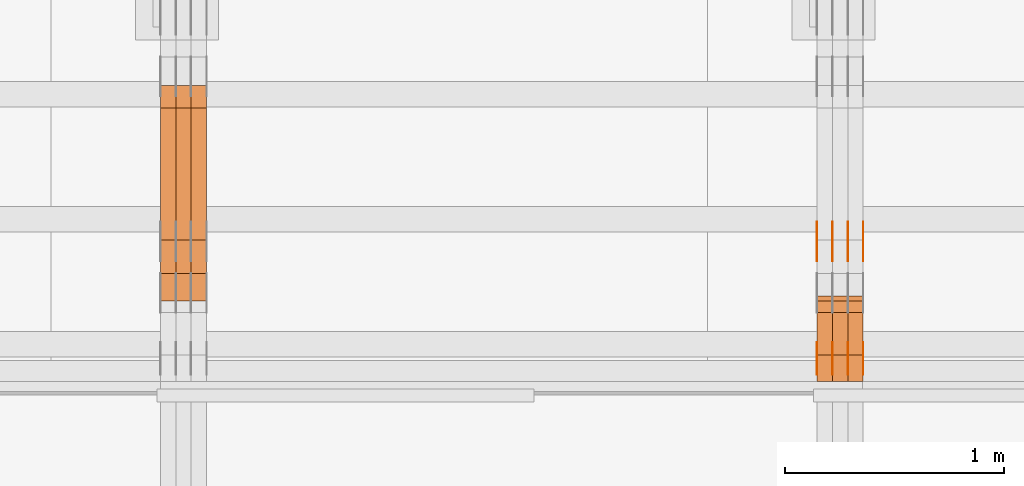
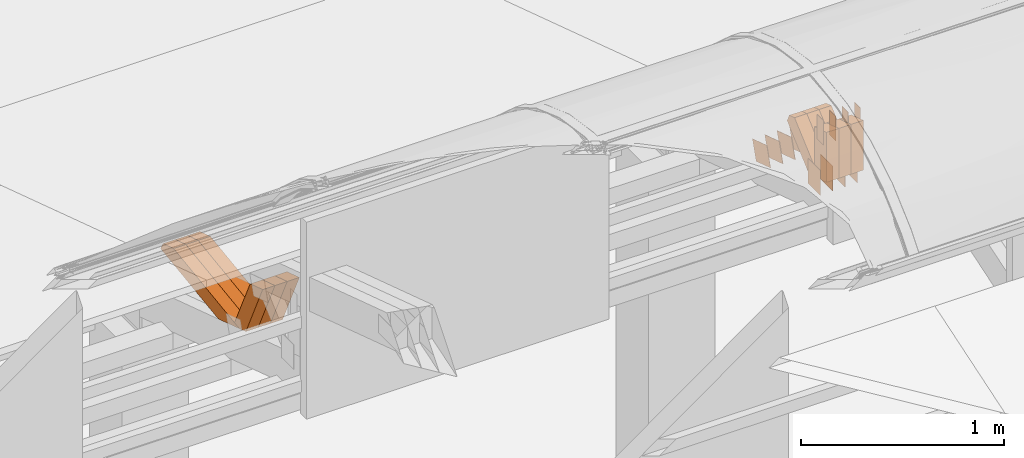
# One storey, part 162 of 385: 30 proxies.
"""IFC2X3 building model written with IfcOpenShell, lengths in millimetres."""

import ifcopenshell
import ifcopenshell.guid

model = None  # the IFC model being written
_history = None  # IfcOwnerHistory: only IFC2X3 demands one
_inside = {}  # id of a spatial element -> (the spatial element, [elements in it])
_under = {}  # id of a project, library or spatial element -> (it, [spatial elements below it])
_declared = {}  # id of a project -> (the project, [libraries it declares])
_typed = {}  # id of a type object -> (the type object, [elements of that type])
_made_of = {}  # id of a material, layer set ... -> (it, [elements and type objects made of it])


def new_model(schema):
    """Start an empty IFC model of exactly this schema.

    Asked for "IFC4X3", IfcOpenShell would pick the latest addendum, in which some entities
    have other attributes; the version numbers below select the first issue.
    IFC2X3 requires an IfcOwnerHistory on every rooted entity: one is made here for all.
    """
    global model, _history
    if schema == "IFC4X3":
        model = ifcopenshell.file(schema_version=(4, 3, 0, 0))
    else:
        model = ifcopenshell.file(schema=schema)
    _inside.clear()
    _under.clear()
    _declared.clear()
    _typed.clear()
    _made_of.clear()
    _history = None
    if model.schema == "IFC2X3":
        org = make("IfcOrganization", Name="unknown")
        user = make(
            "IfcPersonAndOrganization",
            ThePerson=make("IfcPerson", FamilyName="unknown"),
            TheOrganization=org,
        )
        app = make(
            "IfcApplication",
            ApplicationDeveloper=org,
            Version="unknown",
            ApplicationFullName="unknown",
            ApplicationIdentifier="unknown",
        )
        _history = make(
            "IfcOwnerHistory",
            OwningUser=user,
            OwningApplication=app,
            ChangeAction="ADDED",
            CreationDate=0,
        )
    return model


def make(cls, **values):
    """One entity of the class cls with the attributes given. An attribute that is None is left unset."""
    return model.create_entity(
        cls, **{name: value for name, value in values.items() if value is not None}
    )


def entity(cls, *values):
    """Any entity or typed value of the class cls, its attributes in the order of the schema. None: left unset."""
    e = model.create_entity(cls)
    for i, value in enumerate(values):
        if value is not None:
            e[i] = value
    return e


def rooted(cls, **values):
    """An entity with a GlobalId (a new one), such as an element, a storey or a relation."""
    return make(cls, GlobalId=ifcopenshell.guid.new(), OwnerHistory=_history, **values)


def si_unit(unit_type, name, prefix=None):
    """IfcSIUnit, for example si_unit("LENGTHUNIT", "METRE", prefix="MILLI")."""
    return make("IfcSIUnit", UnitType=unit_type, Prefix=prefix, Name=name)


def converted_unit(unit_type, name, factor, base, dimensions=None, offset=None):
    """IfcConversionBasedUnit, such as the inch: factor (a typed value) times the base unit."""
    return make(
        "IfcConversionBasedUnit"
        if offset is None
        else "IfcConversionBasedUnitWithOffset",
        ConversionOffset=offset,
        Dimensions=None
        if dimensions is None
        else entity("IfcDimensionalExponents", *dimensions),
        UnitType=unit_type,
        Name=name,
        ConversionFactor=make(
            "IfcMeasureWithUnit", ValueComponent=factor, UnitComponent=base
        ),
    )


def derived_unit(unit_type, elements):
    """IfcDerivedUnit: a product of units, each with its exponent."""
    return make(
        "IfcDerivedUnit",
        Elements=[
            make("IfcDerivedUnitElement", Unit=unit, Exponent=power)
            for unit, power in elements
        ],
        UnitType=unit_type,
    )


def assignment(units):
    """IfcUnitAssignment: the units of a project."""
    return None if units is None else make("IfcUnitAssignment", Units=units)


def point(xyz):
    """IfcCartesianPoint."""
    return None if xyz is None else make("IfcCartesianPoint", Coordinates=xyz)


def direction(xyz):
    """IfcDirection."""
    return None if xyz is None else make("IfcDirection", DirectionRatios=xyz)


def frame(location, z_axis=None, x_axis=None):
    """IfcAxis2Placement3D, a coordinate frame: its origin and axes. An axis left out is left unset."""
    return make(
        "IfcAxis2Placement3D",
        Location=point(location),
        Axis=direction(z_axis),
        RefDirection=direction(x_axis),
    )


def frame_2d(location, x_axis=None):
    """IfcAxis2Placement2D, a coordinate frame in the plane: its origin and x axis."""
    return make(
        "IfcAxis2Placement2D", Location=point(location), RefDirection=direction(x_axis)
    )


def origin():
    """The frame at (0, 0, 0) with its axes left unset."""
    return frame((0.0, 0.0, 0.0))


def origin_2d_with_axis():
    """The frame at (0, 0) in the plane with the x axis (1, 0) written out."""
    return frame_2d((0.0, 0.0), x_axis=(1.0, 0.0))


def place(relative_to, where):
    """IfcLocalPlacement: puts the frame where relative to a parent placement (None: the world)."""
    return make(
        "IfcLocalPlacement", PlacementRelTo=relative_to, RelativePlacement=where
    )


def context(
    kind, dimensions, precision=None, world=None, true_north=None, identifier=None
):
    """IfcGeometricRepresentationContext, for example the 3D "Model" context."""
    return make(
        "IfcGeometricRepresentationContext",
        ContextIdentifier=identifier,
        ContextType=kind,
        CoordinateSpaceDimension=dimensions,
        Precision=precision,
        WorldCoordinateSystem=world,
        TrueNorth=true_north,
    )


def subcontext(parent, identifier, kind, view, scale=None):
    """IfcGeometricRepresentationSubContext, for example "Body" below "Model"."""
    return make(
        "IfcGeometricRepresentationSubContext",
        ContextIdentifier=identifier,
        ContextType=kind,
        ParentContext=parent,
        TargetScale=scale,
        TargetView=view,
    )


def project(units=None, contexts=None):
    """IfcProject with its units and contexts."""
    return rooted(
        "IfcProject",
        Name="project",
        RepresentationContexts=contexts,
        UnitsInContext=assignment(units),
    )


def spatial(cls, under=None, at=None, **own):
    """A site, building, storey or space (cls), placed at a placement, below another one or the project."""
    s = rooted(cls, ObjectPlacement=at, **own)
    if under is not None:
        _under.setdefault(under.id(), (under, []))[1].append(s)
    return s


def polyline(points):
    """IfcPolyline through the points."""
    return make("IfcPolyline", Points=[point(p) for p in points])


def profile(cls, at=None, kind="AREA", **sizes):
    """A parametric profile (cls). Its sizes go by their IFC names, for example OverallWidth=200.0."""
    return make(cls, ProfileType=kind, Position=at, **sizes)


def rectangle(**sizes):
    """IfcRectangleProfileDef."""
    return profile("IfcRectangleProfileDef", **sizes)


def outline(outer, holes=None, kind="AREA"):
    """IfcArbitraryClosedProfileDef: a profile drawn as a closed curve; with holes, ...WithVoids."""
    if holes is None:
        return make("IfcArbitraryClosedProfileDef", ProfileType=kind, OuterCurve=outer)
    return make(
        "IfcArbitraryProfileDefWithVoids",
        ProfileType=kind,
        OuterCurve=outer,
        InnerCurves=holes,
    )


def extrude(swept, where, along, depth):
    """IfcExtrudedAreaSolid: the profile swept, set in the frame where, extruded along a direction by depth."""
    return make(
        "IfcExtrudedAreaSolid",
        SweptArea=swept,
        Position=where,
        ExtrudedDirection=direction(along),
        Depth=depth,
    )


def shape(context_of_items, identifier, shape_type, items):
    """IfcShapeRepresentation: the items that make up one representation, for example the "Body"."""
    return make(
        "IfcShapeRepresentation",
        ContextOfItems=context_of_items,
        RepresentationIdentifier=identifier,
        RepresentationType=shape_type,
        Items=items,
    )


def source(mapping_origin, context_of_items, identifier, shape_type, items):
    """IfcRepresentationMap: a shape defined once, which mapped items show again and again."""
    return make(
        "IfcRepresentationMap",
        MappingOrigin=mapping_origin,
        MappedRepresentation=shape(context_of_items, identifier, shape_type, items),
    )


def transform(
    local_origin,
    x_axis=None,
    y_axis=None,
    z_axis=None,
    scale=None,
    scale2=None,
    scale3=None,
    uniform=True,
):
    """IfcCartesianTransformationOperator3D, or its non-uniform kind. x_axis, y_axis, z_axis: its Axis1, 2, 3."""
    if uniform:
        return make(
            "IfcCartesianTransformationOperator3D",
            Axis1=direction(x_axis),
            Axis2=direction(y_axis),
            LocalOrigin=point(local_origin),
            Scale=scale,
            Axis3=direction(z_axis),
        )
    return make(
        "IfcCartesianTransformationOperator3DnonUniform",
        Axis1=direction(x_axis),
        Axis2=direction(y_axis),
        LocalOrigin=point(local_origin),
        Scale=scale,
        Axis3=direction(z_axis),
        Scale2=scale2,
        Scale3=scale3,
    )


def mapped(mapping_source, mapping_target):
    """IfcMappedItem: shows the shape of a source again, moved by a transform."""
    return make(
        "IfcMappedItem", MappingSource=mapping_source, MappingTarget=mapping_target
    )


def material(Name=None, Category=None):
    """IfcMaterial."""
    return make("IfcMaterial", Name=Name, Category=Category)


def made_of(thing, what):
    """Note that an element or type object is made of a material, layer set ...; save() writes the relation."""
    if what is not None:
        _made_of.setdefault(what.id(), (what, []))[1].append(thing)
    return thing


def type_object(cls, material=None, **own):
    """A type object (cls), such as IfcWallType, which elements share."""
    return made_of(rooted(cls, **own), material)


def type_shapes(of_type, sources):
    """Give a type object the sources (RepresentationMaps) that its elements show as mapped items."""
    of_type.RepresentationMaps = sources


def element(
    cls,
    number,
    at=None,
    inside=None,
    cuts=None,
    type_object=None,
    material=None,
    context=None,
    identifier="Body",
    shape_type=None,
    held_by="IfcProductDefinitionShape",
    body=None,
    shapes=None,
    **own,
):
    """One element of the class cls, such as IfcWall. Its Tag is "e" and its number.

    at: its placement. inside: the storey or other place that contains it. cuts: it is an
    opening in that element (IfcRelVoidsElement). A single representation is given by context,
    identifier, shape_type and body (its items); several are given by shapes. held_by: the class
    of the entity that holds the representations. save() writes the other relations.
    """
    e = rooted(cls, Tag="e%d" % number, ObjectPlacement=at, **own)
    if body is not None:
        shapes = [shape(context, identifier, shape_type, body)]
    if shapes is not None:
        e.Representation = make(held_by, Representations=shapes)
    if inside is not None:
        _inside.setdefault(inside.id(), (inside, []))[1].append(e)
    if cuts is not None:
        rooted(
            "IfcRelVoidsElement", RelatingBuildingElement=cuts, RelatedOpeningElement=e
        )
    if type_object is not None:
        _typed.setdefault(type_object.id(), (type_object, []))[1].append(e)
    return made_of(e, material)


def aggregate(whole, parts):
    """IfcRelAggregates: a whole, such as a stair, and the parts it consists of."""
    return rooted("IfcRelAggregates", RelatingObject=whole, RelatedObjects=parts)


def save(model, path):
    """Write the relations noted so far, then the file.

    IfcRelAggregates (storeys below a building ...), IfcRelContainedInSpatialStructure (elements
    in a storey), IfcRelDefinesByType, IfcRelAssociatesMaterial and IfcRelDeclares: one each for
    every whole, place, type object, material and project.
    """
    for whole, parts in _under.values():
        aggregate(whole, parts)
    for where, things in _inside.values():
        rooted(
            "IfcRelContainedInSpatialStructure",
            RelatedElements=things,
            RelatingStructure=where,
        )
    for kind, things in _typed.values():
        rooted("IfcRelDefinesByType", RelatedObjects=things, RelatingType=kind)
    for what, things in _made_of.values():
        rooted("IfcRelAssociatesMaterial", RelatedObjects=things, RelatingMaterial=what)
    for by, libraries in _declared.values():
        rooted("IfcRelDeclares", RelatingContext=by, RelatedDefinitions=libraries)
    model.write(path)


model = new_model("IFC2X3")

# Units and contexts
model_context = context("Model", 3, precision=0.01, world=origin(), true_north=direction((6.12303176911189e-17, 1.0)))
body_context = subcontext(model_context, "Body", "Model", "MODEL_VIEW")
ifc_project = project(units=[si_unit("LENGTHUNIT", "METRE", prefix="MILLI"), si_unit("AREAUNIT", "SQUARE_METRE"), si_unit("VOLUMEUNIT", "CUBIC_METRE"), converted_unit("PLANEANGLEUNIT", "DEGREE", entity("IfcRatioMeasure", 0.0174532925199433), si_unit("PLANEANGLEUNIT", "RADIAN"), dimensions=[0, 0, 0, 0, 0, 0, 0]), si_unit("MASSUNIT", "GRAM", prefix="KILO"), derived_unit("MASSDENSITYUNIT", [(si_unit("MASSUNIT", "GRAM", prefix="KILO"), 1), (si_unit("LENGTHUNIT", "METRE"), -3)]), si_unit("TIMEUNIT", "SECOND"), si_unit("FREQUENCYUNIT", "HERTZ"), si_unit("THERMODYNAMICTEMPERATUREUNIT", "DEGREE_CELSIUS"), derived_unit("THERMALTRANSMITTANCEUNIT", [(si_unit("MASSUNIT", "GRAM", prefix="KILO"), 1), (si_unit("THERMODYNAMICTEMPERATUREUNIT", "KELVIN"), -1), (si_unit("TIMEUNIT", "SECOND"), -3)]), derived_unit("VOLUMETRICFLOWRATEUNIT", [(si_unit("LENGTHUNIT", "METRE"), 3), (si_unit("TIMEUNIT", "SECOND"), -1)]), si_unit("ELECTRICCURRENTUNIT", "AMPERE"), si_unit("ELECTRICVOLTAGEUNIT", "VOLT"), si_unit("POWERUNIT", "WATT"), si_unit("FORCEUNIT", "NEWTON", prefix="KILO"), si_unit("ILLUMINANCEUNIT", "LUX"), si_unit("LUMINOUSFLUXUNIT", "LUMEN"), si_unit("LUMINOUSINTENSITYUNIT", "CANDELA"), derived_unit("USERDEFINED", [(si_unit("MASSUNIT", "GRAM", prefix="KILO"), -1), (si_unit("LENGTHUNIT", "METRE"), -2), (si_unit("TIMEUNIT", "SECOND"), 3), (si_unit("LUMINOUSFLUXUNIT", "LUMEN"), 1)]), derived_unit("LINEARVELOCITYUNIT", [(si_unit("LENGTHUNIT", "METRE"), 1), (si_unit("TIMEUNIT", "SECOND"), -1)]), si_unit("PRESSUREUNIT", "PASCAL"), derived_unit("USERDEFINED", [(si_unit("LENGTHUNIT", "METRE"), -2), (si_unit("MASSUNIT", "GRAM", prefix="KILO"), 1), (si_unit("TIMEUNIT", "SECOND"), -2)])], contexts=[model_context])

# Site, building, storey
site_placement = place(None, origin())
site = spatial("IfcSite", under=ifc_project, at=site_placement, CompositionType="ELEMENT")
building_placement = place(site_placement, origin())
building = spatial("IfcBuilding", under=site, at=building_placement, CompositionType="ELEMENT")
storey_placement = place(building_placement, origin())
storey = spatial("IfcBuildingStorey", under=building, at=storey_placement, Name="Default", CompositionType="ELEMENT", Elevation=0.0)

# Proxies
ifc_material_1 = material(Name="IfcSurfaceStyle #343106")
building_element_proxy_type_1 = type_object("IfcBuildingElementProxyType", PredefinedType="NOTDEFINED", material=ifc_material_1)
shared_shape_1 = source(origin(), body_context, "Body", "SweptSolid", [
    extrude(rectangle(XDim=150.0, YDim=120.0, at=origin_2d_with_axis()), frame((75.0, 60.0, 0.0), z_axis=(0.0, 0.0, 1.0), x_axis=(-1.0, 0.0, 0.0)), (0.0, 0.0, 1.0), 1.3),
])
type_shapes(building_element_proxy_type_1, [shared_shape_1])
proxy_1_placement = place(building_placement, frame((27386.3, 15840.0, 3652.70166015625), z_axis=(-1.0, 0.0, 0.0), x_axis=(0.0, 0.0, -1.0)))
element("IfcBuildingElementProxy", 1, at=proxy_1_placement, inside=storey, type_object=building_element_proxy_type_1, material=ifc_material_1, context=body_context, shape_type="MappedRepresentation", body=[
    mapped(shared_shape_1, transform((0.0, 0.0, 0.0), scale=1.0)),
])
ifc_material_2 = material(Name="IfcSurfaceStyle #343049")
building_element_proxy_type_2 = type_object("IfcBuildingElementProxyType", PredefinedType="NOTDEFINED", material=ifc_material_2)
shared_shape_2 = source(origin(), body_context, "Body", "SweptSolid", [
    extrude(rectangle(XDim=150.0, YDim=120.0, at=origin_2d_with_axis()), frame((75.0, 60.0, 0.0), z_axis=(0.0, 0.0, 1.0), x_axis=(-1.0, 0.0, 0.0)), (0.0, 0.0, 1.0), 1.3),
])
type_shapes(building_element_proxy_type_2, [shared_shape_2])
proxy_2_placement = place(building_placement, frame((27315.0, 15840.0, 3652.70166015625), z_axis=(-1.0, 0.0, 0.0), x_axis=(0.0, 0.0, -1.0)))
element("IfcBuildingElementProxy", 2, at=proxy_2_placement, inside=storey, type_object=building_element_proxy_type_2, material=ifc_material_2, context=body_context, shape_type="MappedRepresentation", body=[
    mapped(shared_shape_2, transform((0.0, 0.0, 0.0), scale=1.0)),
])
ifc_material_3 = material(Name="IfcSurfaceStyle #342992")
building_element_proxy_type_3 = type_object("IfcBuildingElementProxyType", PredefinedType="NOTDEFINED", material=ifc_material_3)
shared_shape_3 = source(origin(), body_context, "Body", "SweptSolid", [
    extrude(rectangle(XDim=150.0, YDim=120.0, at=origin_2d_with_axis()), frame((75.0, 60.0, 0.0), z_axis=(0.0, 0.0, 1.0), x_axis=(-1.0, 0.0, 0.0)), (0.0, 0.0, 1.0), 1.3),
])
type_shapes(building_element_proxy_type_3, [shared_shape_3])
proxy_3_placement = place(building_placement, frame((27316.3, 15840.0, 3652.70166015625), z_axis=(-1.0, 0.0, 0.0), x_axis=(0.0, 0.0, -1.0)))
element("IfcBuildingElementProxy", 3, at=proxy_3_placement, inside=storey, type_object=building_element_proxy_type_3, material=ifc_material_3, context=body_context, shape_type="MappedRepresentation", body=[
    mapped(shared_shape_3, transform((0.0, 0.0, 0.0), scale=1.0)),
])
ifc_material_4 = material(Name="IfcSurfaceStyle #342935")
building_element_proxy_type_4 = type_object("IfcBuildingElementProxyType", PredefinedType="NOTDEFINED", material=ifc_material_4)
shared_shape_4 = source(origin(), body_context, "Body", "SweptSolid", [
    extrude(rectangle(XDim=150.0, YDim=120.0, at=origin_2d_with_axis()), frame((75.0, 60.0, 0.0), z_axis=(0.0, 0.0, 1.0), x_axis=(-1.0, 0.0, 0.0)), (0.0, 0.0, 1.0), 1.29999999999999),
])
type_shapes(building_element_proxy_type_4, [shared_shape_4])
proxy_4_placement = place(building_placement, frame((27245.0, 15840.0, 3652.70166015625), z_axis=(-1.0, 0.0, 0.0), x_axis=(0.0, 0.0, -1.0)))
element("IfcBuildingElementProxy", 4, at=proxy_4_placement, inside=storey, type_object=building_element_proxy_type_4, material=ifc_material_4, context=body_context, shape_type="MappedRepresentation", body=[
    mapped(shared_shape_4, transform((0.0, 0.0, 0.0), scale=1.0)),
])
ifc_material_5 = material(Name="IfcSurfaceStyle #342878")
building_element_proxy_type_5 = type_object("IfcBuildingElementProxyType", PredefinedType="NOTDEFINED", material=ifc_material_5)
shared_shape_5 = source(origin(), body_context, "Body", "SweptSolid", [
    extrude(rectangle(XDim=150.0, YDim=120.0, at=origin_2d_with_axis()), frame((75.0, 60.0, 0.0), z_axis=(0.0, 0.0, 1.0), x_axis=(-1.0, 0.0, 0.0)), (0.0, 0.0, 1.0), 1.29999999999999),
])
type_shapes(building_element_proxy_type_5, [shared_shape_5])
proxy_5_placement = place(building_placement, frame((27246.3, 15840.0, 3652.70166015625), z_axis=(-1.0, 0.0, 0.0), x_axis=(0.0, 0.0, -1.0)))
element("IfcBuildingElementProxy", 5, at=proxy_5_placement, inside=storey, type_object=building_element_proxy_type_5, material=ifc_material_5, context=body_context, shape_type="MappedRepresentation", body=[
    mapped(shared_shape_5, transform((0.0, 0.0, 0.0), scale=1.0)),
])
ifc_material_6 = material(Name="IfcSurfaceStyle #342821")
building_element_proxy_type_6 = type_object("IfcBuildingElementProxyType", PredefinedType="NOTDEFINED", material=ifc_material_6)
shared_shape_6 = source(origin(), body_context, "Body", "SweptSolid", [
    extrude(rectangle(XDim=150.0, YDim=120.0, at=origin_2d_with_axis()), frame((75.0, 60.0, 0.0), z_axis=(0.0, 0.0, 1.0), x_axis=(-1.0, 0.0, 0.0)), (0.0, 0.0, 1.0), 1.29999999999999),
])
type_shapes(building_element_proxy_type_6, [shared_shape_6])
proxy_6_placement = place(building_placement, frame((27175.0, 15840.0, 3652.70166015625), z_axis=(-1.0, 0.0, 0.0), x_axis=(0.0, 0.0, -1.0)))
element("IfcBuildingElementProxy", 6, at=proxy_6_placement, inside=storey, type_object=building_element_proxy_type_6, material=ifc_material_6, context=body_context, shape_type="MappedRepresentation", body=[
    mapped(shared_shape_6, transform((0.0, 0.0, 0.0), scale=1.0)),
])
ifc_material_7 = material(Name="IfcSurfaceStyle #342764")
building_element_proxy_type_7 = type_object("IfcBuildingElementProxyType", PredefinedType="NOTDEFINED", material=ifc_material_7)
shared_shape_7 = source(origin(), body_context, "Body", "SweptSolid", [
    extrude(outline(polyline([(-74.9998605591118, -59.9999264677601), (74.9998754286171, -59.9999264677601), (74.9998605591118, 59.9999264677602), (-74.9998754286171, 59.9999264677602), (-74.9998605591118, -59.9999264677601)])), frame((74.9998754286171, 60.0000503992849, 0.0), z_axis=(0.0, 0.0, 1.0), x_axis=(-1.0, 0.0, 0.0)), (0.0, 0.0, 1.0), 1.3),
])
type_shapes(building_element_proxy_type_7, [shared_shape_7])
proxy_7_placement = place(building_placement, frame((27386.3, 16352.8320303235, 3323.23212676408), z_axis=(-1.0, 0.0, 0.0), x_axis=(0.0, -0.951056516295124, 0.309016994375039)))
element("IfcBuildingElementProxy", 7, at=proxy_7_placement, inside=storey, type_object=building_element_proxy_type_7, material=ifc_material_7, context=body_context, shape_type="MappedRepresentation", body=[
    mapped(shared_shape_7, transform((0.0, 0.0, 0.0), scale=1.0)),
])
ifc_material_8 = material(Name="IfcSurfaceStyle #342707")
building_element_proxy_type_8 = type_object("IfcBuildingElementProxyType", PredefinedType="NOTDEFINED", material=ifc_material_8)
shared_shape_8 = source(origin(), body_context, "Body", "SweptSolid", [
    extrude(outline(polyline([(-74.9998605591118, -59.9999264677601), (74.9998754286171, -59.9999264677601), (74.9998605591118, 59.9999264677602), (-74.9998754286171, 59.9999264677602), (-74.9998605591118, -59.9999264677601)])), frame((74.9998754286171, 60.0000503992849, 0.0), z_axis=(0.0, 0.0, 1.0), x_axis=(-1.0, 0.0, 0.0)), (0.0, 0.0, 1.0), 1.3),
])
type_shapes(building_element_proxy_type_8, [shared_shape_8])
proxy_8_placement = place(building_placement, frame((27315.0, 16352.8320303235, 3323.23212676408), z_axis=(-1.0, 0.0, 0.0), x_axis=(0.0, -0.951056516295124, 0.309016994375039)))
element("IfcBuildingElementProxy", 8, at=proxy_8_placement, inside=storey, type_object=building_element_proxy_type_8, material=ifc_material_8, context=body_context, shape_type="MappedRepresentation", body=[
    mapped(shared_shape_8, transform((0.0, 0.0, 0.0), scale=1.0)),
])
ifc_material_9 = material(Name="IfcSurfaceStyle #342650")
building_element_proxy_type_9 = type_object("IfcBuildingElementProxyType", PredefinedType="NOTDEFINED", material=ifc_material_9)
shared_shape_9 = source(origin(), body_context, "Body", "SweptSolid", [
    extrude(outline(polyline([(-74.9998605591118, -59.9999264677601), (74.9998754286171, -59.9999264677601), (74.9998605591118, 59.9999264677602), (-74.9998754286171, 59.9999264677602), (-74.9998605591118, -59.9999264677601)])), frame((74.9998754286171, 60.0000503992849, 0.0), z_axis=(0.0, 0.0, 1.0), x_axis=(-1.0, 0.0, 0.0)), (0.0, 0.0, 1.0), 1.3),
])
type_shapes(building_element_proxy_type_9, [shared_shape_9])
proxy_9_placement = place(building_placement, frame((27316.3, 16352.8320303235, 3323.23212676408), z_axis=(-1.0, 0.0, 0.0), x_axis=(0.0, -0.951056516295124, 0.309016994375039)))
element("IfcBuildingElementProxy", 9, at=proxy_9_placement, inside=storey, type_object=building_element_proxy_type_9, material=ifc_material_9, context=body_context, shape_type="MappedRepresentation", body=[
    mapped(shared_shape_9, transform((0.0, 0.0, 0.0), scale=1.0)),
])
ifc_material_10 = material(Name="IfcSurfaceStyle #342593")
building_element_proxy_type_10 = type_object("IfcBuildingElementProxyType", PredefinedType="NOTDEFINED", material=ifc_material_10)
shared_shape_10 = source(origin(), body_context, "Body", "SweptSolid", [
    extrude(outline(polyline([(-74.9998605591118, -59.9999264677601), (74.9998754286171, -59.9999264677601), (74.9998605591118, 59.9999264677602), (-74.9998754286171, 59.9999264677602), (-74.9998605591118, -59.9999264677601)])), frame((74.9998754286171, 60.0000503992849, 0.0), z_axis=(0.0, 0.0, 1.0), x_axis=(-1.0, 0.0, 0.0)), (0.0, 0.0, 1.0), 1.29999999999999),
])
type_shapes(building_element_proxy_type_10, [shared_shape_10])
proxy_10_placement = place(building_placement, frame((27245.0, 16352.8320303235, 3323.23212676408), z_axis=(-1.0, 0.0, 0.0), x_axis=(0.0, -0.951056516295124, 0.309016994375039)))
element("IfcBuildingElementProxy", 10, at=proxy_10_placement, inside=storey, type_object=building_element_proxy_type_10, material=ifc_material_10, context=body_context, shape_type="MappedRepresentation", body=[
    mapped(shared_shape_10, transform((0.0, 0.0, 0.0), scale=1.0)),
])
ifc_material_11 = material(Name="IfcSurfaceStyle #342536")
building_element_proxy_type_11 = type_object("IfcBuildingElementProxyType", PredefinedType="NOTDEFINED", material=ifc_material_11)
shared_shape_11 = source(origin(), body_context, "Body", "SweptSolid", [
    extrude(outline(polyline([(-74.9998605591118, -59.9999264677601), (74.9998754286171, -59.9999264677601), (74.9998605591118, 59.9999264677602), (-74.9998754286171, 59.9999264677602), (-74.9998605591118, -59.9999264677601)])), frame((74.9998754286171, 60.0000503992849, 0.0), z_axis=(0.0, 0.0, 1.0), x_axis=(-1.0, 0.0, 0.0)), (0.0, 0.0, 1.0), 1.29999999999999),
])
type_shapes(building_element_proxy_type_11, [shared_shape_11])
proxy_11_placement = place(building_placement, frame((27246.3, 16352.8320303235, 3323.23212676408), z_axis=(-1.0, 0.0, 0.0), x_axis=(0.0, -0.951056516295124, 0.309016994375039)))
element("IfcBuildingElementProxy", 11, at=proxy_11_placement, inside=storey, type_object=building_element_proxy_type_11, material=ifc_material_11, context=body_context, shape_type="MappedRepresentation", body=[
    mapped(shared_shape_11, transform((0.0, 0.0, 0.0), scale=1.0)),
])
ifc_material_12 = material(Name="IfcSurfaceStyle #342479")
building_element_proxy_type_12 = type_object("IfcBuildingElementProxyType", PredefinedType="NOTDEFINED", material=ifc_material_12)
shared_shape_12 = source(origin(), body_context, "Body", "SweptSolid", [
    extrude(outline(polyline([(-74.9998605591118, -59.9999264677601), (74.9998754286171, -59.9999264677601), (74.9998605591118, 59.9999264677602), (-74.9998754286171, 59.9999264677602), (-74.9998605591118, -59.9999264677601)])), frame((74.9998754286171, 60.0000503992849, 0.0), z_axis=(0.0, 0.0, 1.0), x_axis=(-1.0, 0.0, 0.0)), (0.0, 0.0, 1.0), 1.29999999999999),
])
type_shapes(building_element_proxy_type_12, [shared_shape_12])
proxy_12_placement = place(building_placement, frame((27175.0, 16352.8320303235, 3323.23212676408), z_axis=(-1.0, 0.0, 0.0), x_axis=(0.0, -0.951056516295124, 0.309016994375039)))
element("IfcBuildingElementProxy", 12, at=proxy_12_placement, inside=storey, type_object=building_element_proxy_type_12, material=ifc_material_12, context=body_context, shape_type="MappedRepresentation", body=[
    mapped(shared_shape_12, transform((0.0, 0.0, 0.0), scale=1.0)),
])
ifc_material_13 = material(Name="IfcSurfaceStyle #337634")
building_element_proxy_type_13 = type_object("IfcBuildingElementProxyType", PredefinedType="NOTDEFINED", material=ifc_material_13)
shared_shape_13 = source(origin(), body_context, "Body", "SweptSolid", [
    extrude(rectangle(XDim=150.0, YDim=60.0, at=origin_2d_with_axis()), frame((75.0000705696311, 30.0, 0.0), z_axis=(0.0, 0.0, 1.0), x_axis=(-1.0, 0.0, 0.0)), (0.0, 0.0, 1.0), 1.3),
])
type_shapes(building_element_proxy_type_13, [shared_shape_13])
proxy_13_placement = place(building_placement, frame((27386.3, 15750.0, 3972.59919166338), z_axis=(-1.0, 0.0, 0.0), x_axis=(0.0, 0.0, -1.0)))
element("IfcBuildingElementProxy", 13, at=proxy_13_placement, inside=storey, type_object=building_element_proxy_type_13, material=ifc_material_13, context=body_context, shape_type="MappedRepresentation", body=[
    mapped(shared_shape_13, transform((0.0, 0.0, 0.0), scale=1.0)),
])
ifc_material_14 = material(Name="IfcSurfaceStyle #337577")
building_element_proxy_type_14 = type_object("IfcBuildingElementProxyType", PredefinedType="NOTDEFINED", material=ifc_material_14)
shared_shape_14 = source(origin(), body_context, "Body", "SweptSolid", [
    extrude(rectangle(XDim=150.0, YDim=60.0, at=origin_2d_with_axis()), frame((75.0000705696311, 30.0, 0.0), z_axis=(0.0, 0.0, 1.0), x_axis=(-1.0, 0.0, 0.0)), (0.0, 0.0, 1.0), 1.3),
])
type_shapes(building_element_proxy_type_14, [shared_shape_14])
proxy_14_placement = place(building_placement, frame((27315.0, 15750.0, 3972.59919166338), z_axis=(-1.0, 0.0, 0.0), x_axis=(0.0, 0.0, -1.0)))
element("IfcBuildingElementProxy", 14, at=proxy_14_placement, inside=storey, type_object=building_element_proxy_type_14, material=ifc_material_14, context=body_context, shape_type="MappedRepresentation", body=[
    mapped(shared_shape_14, transform((0.0, 0.0, 0.0), scale=1.0)),
])
ifc_material_15 = material(Name="IfcSurfaceStyle #337520")
building_element_proxy_type_15 = type_object("IfcBuildingElementProxyType", PredefinedType="NOTDEFINED", material=ifc_material_15)
shared_shape_15 = source(origin(), body_context, "Body", "SweptSolid", [
    extrude(rectangle(XDim=150.0, YDim=60.0, at=origin_2d_with_axis()), frame((75.0000705696311, 30.0, 0.0), z_axis=(0.0, 0.0, 1.0), x_axis=(-1.0, 0.0, 0.0)), (0.0, 0.0, 1.0), 1.3),
])
type_shapes(building_element_proxy_type_15, [shared_shape_15])
proxy_15_placement = place(building_placement, frame((27316.3, 15750.0, 3972.59919166338), z_axis=(-1.0, 0.0, 0.0), x_axis=(0.0, 0.0, -1.0)))
element("IfcBuildingElementProxy", 15, at=proxy_15_placement, inside=storey, type_object=building_element_proxy_type_15, material=ifc_material_15, context=body_context, shape_type="MappedRepresentation", body=[
    mapped(shared_shape_15, transform((0.0, 0.0, 0.0), scale=1.0)),
])
ifc_material_16 = material(Name="IfcSurfaceStyle #337463")
building_element_proxy_type_16 = type_object("IfcBuildingElementProxyType", PredefinedType="NOTDEFINED", material=ifc_material_16)
shared_shape_16 = source(origin(), body_context, "Body", "SweptSolid", [
    extrude(rectangle(XDim=150.0, YDim=60.0, at=origin_2d_with_axis()), frame((75.0000705696311, 30.0, 0.0), z_axis=(0.0, 0.0, 1.0), x_axis=(-1.0, 0.0, 0.0)), (0.0, 0.0, 1.0), 1.29999999999999),
])
type_shapes(building_element_proxy_type_16, [shared_shape_16])
proxy_16_placement = place(building_placement, frame((27245.0, 15750.0, 3972.59919166338), z_axis=(-1.0, 0.0, 0.0), x_axis=(0.0, 0.0, -1.0)))
element("IfcBuildingElementProxy", 16, at=proxy_16_placement, inside=storey, type_object=building_element_proxy_type_16, material=ifc_material_16, context=body_context, shape_type="MappedRepresentation", body=[
    mapped(shared_shape_16, transform((0.0, 0.0, 0.0), scale=1.0)),
])
ifc_material_17 = material(Name="IfcSurfaceStyle #337406")
building_element_proxy_type_17 = type_object("IfcBuildingElementProxyType", PredefinedType="NOTDEFINED", material=ifc_material_17)
shared_shape_17 = source(origin(), body_context, "Body", "SweptSolid", [
    extrude(rectangle(XDim=150.0, YDim=60.0, at=origin_2d_with_axis()), frame((75.0000705696311, 30.0, 0.0), z_axis=(0.0, 0.0, 1.0), x_axis=(-1.0, 0.0, 0.0)), (0.0, 0.0, 1.0), 1.29999999999999),
])
type_shapes(building_element_proxy_type_17, [shared_shape_17])
proxy_17_placement = place(building_placement, frame((27246.3, 15750.0, 3972.59919166338), z_axis=(-1.0, 0.0, 0.0), x_axis=(0.0, 0.0, -1.0)))
element("IfcBuildingElementProxy", 17, at=proxy_17_placement, inside=storey, type_object=building_element_proxy_type_17, material=ifc_material_17, context=body_context, shape_type="MappedRepresentation", body=[
    mapped(shared_shape_17, transform((0.0, 0.0, 0.0), scale=1.0)),
])
ifc_material_18 = material(Name="IfcSurfaceStyle #337349")
building_element_proxy_type_18 = type_object("IfcBuildingElementProxyType", PredefinedType="NOTDEFINED", material=ifc_material_18)
shared_shape_18 = source(origin(), body_context, "Body", "SweptSolid", [
    extrude(rectangle(XDim=150.0, YDim=60.0, at=origin_2d_with_axis()), frame((75.0000705696311, 30.0, 0.0), z_axis=(0.0, 0.0, 1.0), x_axis=(-1.0, 0.0, 0.0)), (0.0, 0.0, 1.0), 1.29999999999999),
])
type_shapes(building_element_proxy_type_18, [shared_shape_18])
proxy_18_placement = place(building_placement, frame((27175.0, 15750.0, 3972.59919166338), z_axis=(-1.0, 0.0, 0.0), x_axis=(0.0, 0.0, -1.0)))
element("IfcBuildingElementProxy", 18, at=proxy_18_placement, inside=storey, type_object=building_element_proxy_type_18, material=ifc_material_18, context=body_context, shape_type="MappedRepresentation", body=[
    mapped(shared_shape_18, transform((0.0, 0.0, 0.0), scale=1.0)),
])
ifc_material_19 = material(Name="IfcSurfaceStyle #328265")
building_element_proxy_type_19 = type_object("IfcBuildingElementProxyType", Name="T1-W50 328263", PredefinedType="NOTDEFINED", material=ifc_material_19)
shared_shape_19 = source(origin(), body_context, "Body", "SweptSolid", [
    extrude(outline(polyline([(-128.56619634284, -47.4999385885712), (133.151257249084, -47.4999385885712), (161.172800006526, -0.000129729183733609), (147.291467726413, 47.500068317755), (-142.513973767368, 47.500068317755), (-170.535354871815, -0.000129729183754689), (-128.56619634284, -47.4999385885712)])), frame((161.17310141218, 47.5001898716564, 0.0), z_axis=(0.0, 0.0, 1.0), x_axis=(-1.0, 0.0, 0.0)), (0.0, 0.0, 1.0), 70.0),
])
type_shapes(building_element_proxy_type_19, [shared_shape_19])
proxy_19_placement = place(building_placement, frame((27385.0, 16060.0297689714, 3761.73994820667), z_axis=(-1.0, 0.0, 0.0), x_axis=(0.0, -0.749388407538668, -0.662130662820156)))
element("IfcBuildingElementProxy", 19, at=proxy_19_placement, inside=storey, type_object=building_element_proxy_type_19, material=ifc_material_19, Name="T1-W50", context=body_context, shape_type="MappedRepresentation", body=[
    mapped(shared_shape_19, transform((0.0, 0.0, 0.0), scale=1.0)),
])
ifc_material_20 = material(Name="IfcSurfaceStyle #328190")
building_element_proxy_type_20 = type_object("IfcBuildingElementProxyType", Name="T1-W50 328188", PredefinedType="NOTDEFINED", material=ifc_material_20)
shared_shape_20 = source(origin(), body_context, "Body", "SweptSolid", [
    extrude(outline(polyline([(-128.56619634284, -47.4999385885712), (133.151257249084, -47.4999385885712), (161.172800006526, -0.000129729183733609), (147.291467726413, 47.500068317755), (-142.513973767368, 47.500068317755), (-170.535354871815, -0.000129729183754689), (-128.56619634284, -47.4999385885712)])), frame((161.17310141218, 47.5001898716564, 0.0), z_axis=(0.0, 0.0, 1.0), x_axis=(-1.0, 0.0, 0.0)), (0.0, 0.0, 1.0), 70.0),
])
type_shapes(building_element_proxy_type_20, [shared_shape_20])
proxy_20_placement = place(building_placement, frame((27315.0, 16060.0297689714, 3761.73994820667), z_axis=(-1.0, 0.0, 0.0), x_axis=(0.0, -0.749388407538668, -0.662130662820156)))
element("IfcBuildingElementProxy", 20, at=proxy_20_placement, inside=storey, type_object=building_element_proxy_type_20, material=ifc_material_20, Name="T1-W50", context=body_context, shape_type="MappedRepresentation", body=[
    mapped(shared_shape_20, transform((0.0, 0.0, 0.0), scale=1.0)),
])
ifc_material_21 = material(Name="IfcSurfaceStyle #328115")
building_element_proxy_type_21 = type_object("IfcBuildingElementProxyType", Name="T1-W50 328113", PredefinedType="NOTDEFINED", material=ifc_material_21)
shared_shape_21 = source(origin(), body_context, "Body", "SweptSolid", [
    extrude(outline(polyline([(-128.56619634284, -47.4999385885712), (133.151257249084, -47.4999385885712), (161.172800006526, -0.000129729183733609), (147.291467726413, 47.500068317755), (-142.513973767368, 47.500068317755), (-170.535354871815, -0.000129729183754689), (-128.56619634284, -47.4999385885712)])), frame((161.17310141218, 47.5001898716564, 0.0), z_axis=(0.0, 0.0, 1.0), x_axis=(-1.0, 0.0, 0.0)), (0.0, 0.0, 1.0), 70.0),
])
type_shapes(building_element_proxy_type_21, [shared_shape_21])
proxy_21_placement = place(building_placement, frame((27245.0, 16060.0297689714, 3761.73994820667), z_axis=(-1.0, 0.0, 0.0), x_axis=(0.0, -0.749388407538668, -0.662130662820156)))
element("IfcBuildingElementProxy", 21, at=proxy_21_placement, inside=storey, type_object=building_element_proxy_type_21, material=ifc_material_21, Name="T1-W50", context=body_context, shape_type="MappedRepresentation", body=[
    mapped(shared_shape_21, transform((0.0, 0.0, 0.0), scale=1.0)),
])
ifc_material_22 = material(Name="IfcSurfaceStyle #327869")
building_element_proxy_type_22 = type_object("IfcBuildingElementProxyType", Name="T1-W2 327867", PredefinedType="NOTDEFINED", material=ifc_material_22)
shared_shape_22 = source(origin(), body_context, "Body", "SweptSolid", [
    extrude(outline(polyline([(-130.705993652344, -60.0), (169.696350097656, -60.0), (130.706115722656, 60.0), (-169.696472167969, 60.0), (-130.705993652344, -60.0)])), frame((169.696429629256, 60.0, 0.0), z_axis=(0.0, 0.0, 1.0), x_axis=(-1.0, 0.0, 0.0)), (0.0, 0.0, 1.0), 70.0),
])
type_shapes(building_element_proxy_type_22, [shared_shape_22])
proxy_22_placement = place(building_placement, frame((27385.0, 15660.0, 3577.70158062465), z_axis=(-1.0, 0.0, 0.0), x_axis=(0.0, 0.0, 1.0)))
element("IfcBuildingElementProxy", 22, at=proxy_22_placement, inside=storey, type_object=building_element_proxy_type_22, material=ifc_material_22, Name="T1-W2", context=body_context, shape_type="MappedRepresentation", body=[
    mapped(shared_shape_22, transform((0.0, 0.0, 0.0), scale=1.0)),
])
ifc_material_23 = material(Name="IfcSurfaceStyle #327812")
building_element_proxy_type_23 = type_object("IfcBuildingElementProxyType", Name="T1-W2 327810", PredefinedType="NOTDEFINED", material=ifc_material_23)
shared_shape_23 = source(origin(), body_context, "Body", "SweptSolid", [
    extrude(outline(polyline([(-130.705993652344, -60.0), (169.696350097656, -60.0), (130.706115722656, 60.0), (-169.696472167969, 60.0), (-130.705993652344, -60.0)])), frame((169.696429629256, 60.0, 0.0), z_axis=(0.0, 0.0, 1.0), x_axis=(-1.0, 0.0, 0.0)), (0.0, 0.0, 1.0), 70.0),
])
type_shapes(building_element_proxy_type_23, [shared_shape_23])
proxy_23_placement = place(building_placement, frame((27315.0, 15660.0, 3577.70158062465), z_axis=(-1.0, 0.0, 0.0), x_axis=(0.0, 0.0, 1.0)))
element("IfcBuildingElementProxy", 23, at=proxy_23_placement, inside=storey, type_object=building_element_proxy_type_23, material=ifc_material_23, Name="T1-W2", context=body_context, shape_type="MappedRepresentation", body=[
    mapped(shared_shape_23, transform((0.0, 0.0, 0.0), scale=1.0)),
])
ifc_material_24 = material(Name="IfcSurfaceStyle #327755")
building_element_proxy_type_24 = type_object("IfcBuildingElementProxyType", Name="T1-W2 327753", PredefinedType="NOTDEFINED", material=ifc_material_24)
shared_shape_24 = source(origin(), body_context, "Body", "SweptSolid", [
    extrude(outline(polyline([(-130.705993652344, -60.0), (169.696350097656, -60.0), (130.706115722656, 60.0), (-169.696472167969, 60.0), (-130.705993652344, -60.0)])), frame((169.696429629256, 60.0, 0.0), z_axis=(0.0, 0.0, 1.0), x_axis=(-1.0, 0.0, 0.0)), (0.0, 0.0, 1.0), 70.0),
])
type_shapes(building_element_proxy_type_24, [shared_shape_24])
proxy_24_placement = place(building_placement, frame((27245.0, 15660.0, 3577.70158062465), z_axis=(-1.0, 0.0, 0.0), x_axis=(0.0, 0.0, 1.0)))
element("IfcBuildingElementProxy", 24, at=proxy_24_placement, inside=storey, type_object=building_element_proxy_type_24, material=ifc_material_24, Name="T1-W2", context=body_context, shape_type="MappedRepresentation", body=[
    mapped(shared_shape_24, transform((0.0, 0.0, 0.0), scale=1.0)),
])
ifc_material_25 = material(Name="IfcSurfaceStyle #293266")
building_element_proxy_type_25 = type_object("IfcBuildingElementProxyType", Name="T1-W44 293264", PredefinedType="NOTDEFINED", material=ifc_material_25)
shared_shape_25 = source(origin(), body_context, "Body", "SweptSolid", [
    extrude(outline(polyline([(-184.551057772692, -47.4997984945814), (177.527112951531, -47.4997984945814), (162.630077773546, -0.000452497529500495), (118.068221667048, 47.5000247433462), (-273.674354619433, 47.5000247433462), (-184.551057772692, -47.4997984945814)])), frame((177.527112951531, 47.5002721629815, 0.0), z_axis=(0.0, 0.0, 1.0), x_axis=(-1.0, 0.0, 0.0)), (0.0, 0.0, 1.0), 70.0),
])
type_shapes(building_element_proxy_type_25, [shared_shape_25])
proxy_25_placement = place(building_placement, frame((24385.0, 16220.4899216004, 3388.98238154171), z_axis=(-1.0, 0.0, 0.0), x_axis=(0.0, -0.425335045192995, 0.905035965766374)))
element("IfcBuildingElementProxy", 25, at=proxy_25_placement, inside=storey, type_object=building_element_proxy_type_25, material=ifc_material_25, Name="T1-W44", context=body_context, shape_type="MappedRepresentation", body=[
    mapped(shared_shape_25, transform((0.0, 0.0, 0.0), scale=1.0)),
])
ifc_material_26 = material(Name="IfcSurfaceStyle #293200")
building_element_proxy_type_26 = type_object("IfcBuildingElementProxyType", Name="T1-W44 293198", PredefinedType="NOTDEFINED", material=ifc_material_26)
shared_shape_26 = source(origin(), body_context, "Body", "SweptSolid", [
    extrude(outline(polyline([(-184.551057772692, -47.4997984945814), (177.527112951531, -47.4997984945814), (162.630077773546, -0.000452497529500495), (118.068221667048, 47.5000247433462), (-273.674354619433, 47.5000247433462), (-184.551057772692, -47.4997984945814)])), frame((177.527112951531, 47.5002721629815, 0.0), z_axis=(0.0, 0.0, 1.0), x_axis=(-1.0, 0.0, 0.0)), (0.0, 0.0, 1.0), 70.0),
])
type_shapes(building_element_proxy_type_26, [shared_shape_26])
proxy_26_placement = place(building_placement, frame((24315.0, 16220.4899216004, 3388.98238154171), z_axis=(-1.0, 0.0, 0.0), x_axis=(0.0, -0.425335045192995, 0.905035965766374)))
element("IfcBuildingElementProxy", 26, at=proxy_26_placement, inside=storey, type_object=building_element_proxy_type_26, material=ifc_material_26, Name="T1-W44", context=body_context, shape_type="MappedRepresentation", body=[
    mapped(shared_shape_26, transform((0.0, 0.0, 0.0), scale=1.0)),
])
ifc_material_27 = material(Name="IfcSurfaceStyle #293134")
building_element_proxy_type_27 = type_object("IfcBuildingElementProxyType", Name="T1-W44 293132", PredefinedType="NOTDEFINED", material=ifc_material_27)
shared_shape_27 = source(origin(), body_context, "Body", "SweptSolid", [
    extrude(outline(polyline([(-184.551057772692, -47.4997984945814), (177.527112951531, -47.4997984945814), (162.630077773546, -0.000452497529500495), (118.068221667048, 47.5000247433462), (-273.674354619433, 47.5000247433462), (-184.551057772692, -47.4997984945814)])), frame((177.527112951531, 47.5002721629815, 0.0), z_axis=(0.0, 0.0, 1.0), x_axis=(-1.0, 0.0, 0.0)), (0.0, 0.0, 1.0), 70.0),
])
type_shapes(building_element_proxy_type_27, [shared_shape_27])
proxy_27_placement = place(building_placement, frame((24245.0, 16220.4899216004, 3388.98238154171), z_axis=(-1.0, 0.0, 0.0), x_axis=(0.0, -0.425335045192995, 0.905035965766374)))
element("IfcBuildingElementProxy", 27, at=proxy_27_placement, inside=storey, type_object=building_element_proxy_type_27, material=ifc_material_27, Name="T1-W44", context=body_context, shape_type="MappedRepresentation", body=[
    mapped(shared_shape_27, transform((0.0, 0.0, 0.0), scale=1.0)),
])
ifc_material_28 = material(Name="IfcSurfaceStyle #292870")
building_element_proxy_type_28 = type_object("IfcBuildingElementProxyType", Name="T1-W8 292868", PredefinedType="NOTDEFINED", material=ifc_material_28)
shared_shape_28 = source(origin(), body_context, "Body", "SweptSolid", [
    extrude(outline(polyline([(-476.725263324644, -47.5001051695965), (180.672765845439, -47.5001051695965), (279.11020091716, -1.03605560390907e-06), (296.793624402619, 47.5001056876243), (-279.851327840575, 47.5001056876243), (-476.725263324644, -47.5001051695965)])), frame((296.793624402619, 47.5001056876243, 0.0), z_axis=(0.0, 0.0, 1.0), x_axis=(-1.0, 0.0, 0.0)), (0.0, 0.0, 1.0), 70.0),
])
type_shapes(building_element_proxy_type_28, [shared_shape_28])
proxy_28_placement = place(building_placement, frame((24385.0, 17036.40625, 3432.97192382813), z_axis=(-1.0, 0.0, 0.0), x_axis=(0.0, -0.990844046556832, -0.135011389900564)))
element("IfcBuildingElementProxy", 28, at=proxy_28_placement, inside=storey, type_object=building_element_proxy_type_28, material=ifc_material_28, Name="T1-W8", context=body_context, shape_type="MappedRepresentation", body=[
    mapped(shared_shape_28, transform((0.0, 0.0, 0.0), scale=1.0)),
])
ifc_material_29 = material(Name="IfcSurfaceStyle #292804")
building_element_proxy_type_29 = type_object("IfcBuildingElementProxyType", Name="T1-W8 292802", PredefinedType="NOTDEFINED", material=ifc_material_29)
shared_shape_29 = source(origin(), body_context, "Body", "SweptSolid", [
    extrude(outline(polyline([(-476.725263324644, -47.5001051695965), (180.672765845439, -47.5001051695965), (279.11020091716, -1.03605560390907e-06), (296.793624402619, 47.5001056876243), (-279.851327840575, 47.5001056876243), (-476.725263324644, -47.5001051695965)])), frame((296.793624402619, 47.5001056876243, 0.0), z_axis=(0.0, 0.0, 1.0), x_axis=(-1.0, 0.0, 0.0)), (0.0, 0.0, 1.0), 70.0),
])
type_shapes(building_element_proxy_type_29, [shared_shape_29])
proxy_29_placement = place(building_placement, frame((24315.0, 17036.40625, 3432.97192382813), z_axis=(-1.0, 0.0, 0.0), x_axis=(0.0, -0.990844046556832, -0.135011389900564)))
element("IfcBuildingElementProxy", 29, at=proxy_29_placement, inside=storey, type_object=building_element_proxy_type_29, material=ifc_material_29, Name="T1-W8", context=body_context, shape_type="MappedRepresentation", body=[
    mapped(shared_shape_29, transform((0.0, 0.0, 0.0), scale=1.0)),
])
ifc_material_30 = material(Name="IfcSurfaceStyle #292738")
building_element_proxy_type_30 = type_object("IfcBuildingElementProxyType", Name="T1-W8 292736", PredefinedType="NOTDEFINED", material=ifc_material_30)
shared_shape_30 = source(origin(), body_context, "Body", "SweptSolid", [
    extrude(outline(polyline([(-476.725263324644, -47.5001051695965), (180.672765845439, -47.5001051695965), (279.11020091716, -1.03605560390907e-06), (296.793624402619, 47.5001056876243), (-279.851327840575, 47.5001056876243), (-476.725263324644, -47.5001051695965)])), frame((296.793624402619, 47.5001056876243, 0.0), z_axis=(0.0, 0.0, 1.0), x_axis=(-1.0, 0.0, 0.0)), (0.0, 0.0, 1.0), 70.0),
])
type_shapes(building_element_proxy_type_30, [shared_shape_30])
proxy_30_placement = place(building_placement, frame((24245.0, 17036.40625, 3432.97192382813), z_axis=(-1.0, 0.0, 0.0), x_axis=(0.0, -0.990844046556832, -0.135011389900564)))
element("IfcBuildingElementProxy", 30, at=proxy_30_placement, inside=storey, type_object=building_element_proxy_type_30, material=ifc_material_30, Name="T1-W8", context=body_context, shape_type="MappedRepresentation", body=[
    mapped(shared_shape_30, transform((0.0, 0.0, 0.0), scale=1.0)),
])

save(model, "model.ifc")
